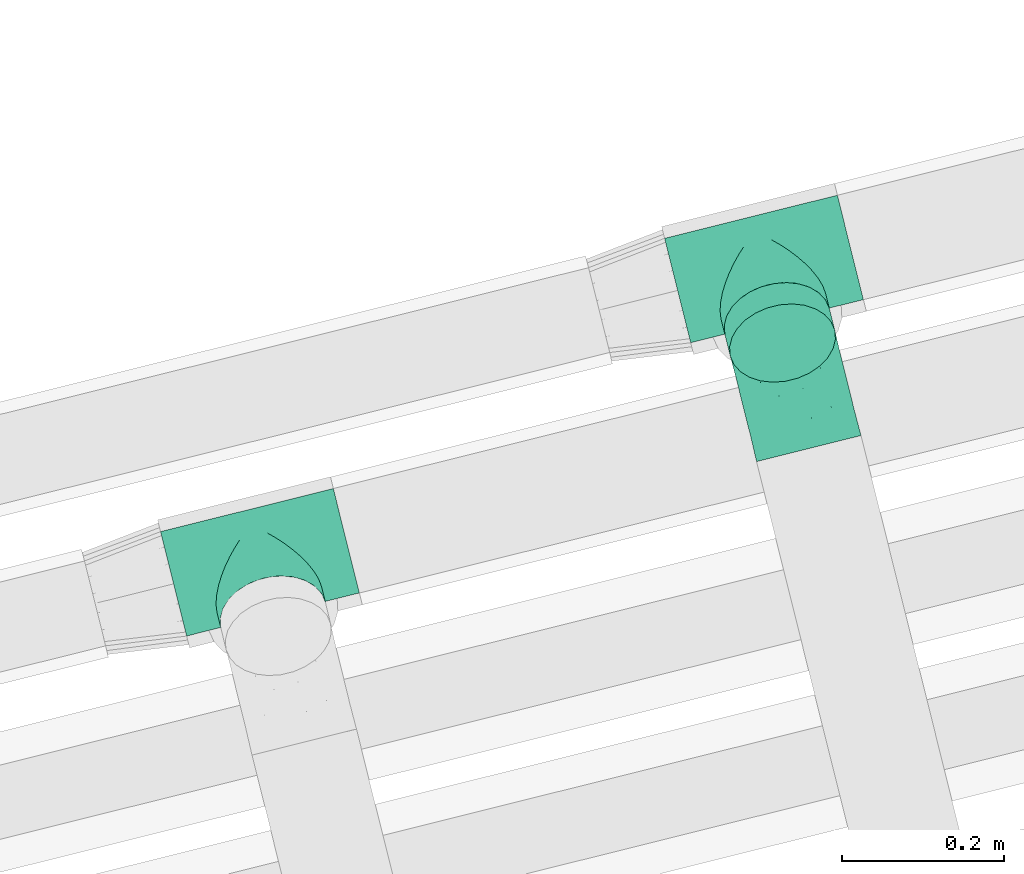
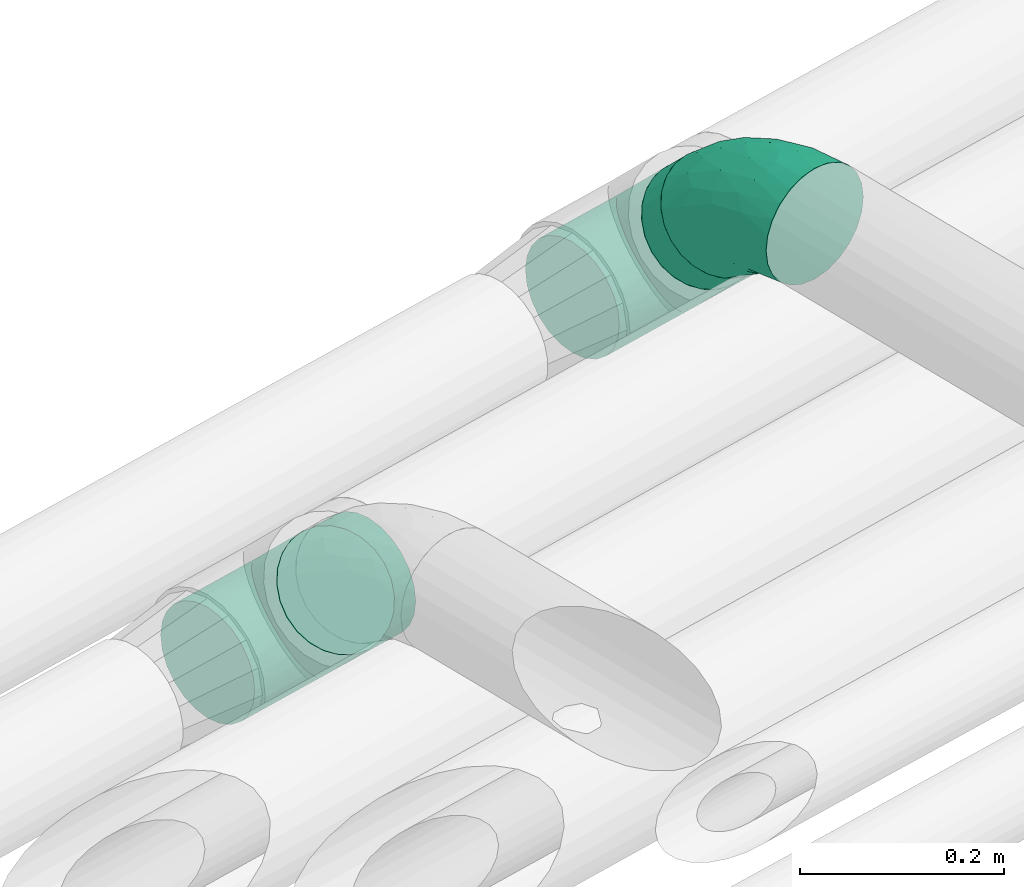
# One storey, part 55 of 93: 3 flow fittings, 1 flow segment.
"""IFC2X3 building model written with IfcOpenShell, lengths in millimetres."""

from ifc_helpers import new_model, entity, si_unit, converted_unit, derived_unit, direction, frame, origin, origin_2d_with_axis, place, context, subcontext, project, spatial, circle, extrude, faceted_brep, source, transform, mapped, material, type_object, type_shapes, element, save


model = new_model("IFC2X3")

# Units and contexts
model_context = context("Model", 3, precision=0.01, world=origin(), true_north=direction((6.12303176911189e-17, 1.0)))
body_context = subcontext(model_context, "Body", "Model", "MODEL_VIEW")
ifc_project = project(units=[si_unit("LENGTHUNIT", "METRE", prefix="MILLI"), si_unit("AREAUNIT", "SQUARE_METRE"), si_unit("VOLUMEUNIT", "CUBIC_METRE"), converted_unit("PLANEANGLEUNIT", "DEGREE", entity("IfcRatioMeasure", 0.0174532925199433), si_unit("PLANEANGLEUNIT", "RADIAN"), dimensions=[0, 0, 0, 0, 0, 0, 0]), si_unit("MASSUNIT", "GRAM", prefix="KILO"), derived_unit("MASSDENSITYUNIT", [(si_unit("MASSUNIT", "GRAM", prefix="KILO"), 1), (si_unit("LENGTHUNIT", "METRE"), -3)]), derived_unit("MOMENTOFINERTIAUNIT", [(si_unit("LENGTHUNIT", "METRE"), 4)]), si_unit("TIMEUNIT", "SECOND"), si_unit("FREQUENCYUNIT", "HERTZ"), si_unit("THERMODYNAMICTEMPERATUREUNIT", "DEGREE_CELSIUS"), derived_unit("THERMALTRANSMITTANCEUNIT", [(si_unit("MASSUNIT", "GRAM", prefix="KILO"), 1), (si_unit("THERMODYNAMICTEMPERATUREUNIT", "KELVIN"), -1), (si_unit("TIMEUNIT", "SECOND"), -3)]), derived_unit("VOLUMETRICFLOWRATEUNIT", [(si_unit("LENGTHUNIT", "METRE"), 3), (si_unit("TIMEUNIT", "SECOND"), -1)]), derived_unit("MASSFLOWRATEUNIT", [(si_unit("MASSUNIT", "GRAM", prefix="KILO"), 1), (si_unit("TIMEUNIT", "SECOND"), -1)]), derived_unit("ROTATIONALFREQUENCYUNIT", [(si_unit("TIMEUNIT", "SECOND"), -1)]), si_unit("ELECTRICCURRENTUNIT", "AMPERE"), si_unit("ELECTRICVOLTAGEUNIT", "VOLT"), si_unit("POWERUNIT", "WATT"), si_unit("FORCEUNIT", "NEWTON", prefix="KILO"), si_unit("ILLUMINANCEUNIT", "LUX"), si_unit("LUMINOUSFLUXUNIT", "LUMEN"), si_unit("LUMINOUSINTENSITYUNIT", "CANDELA"), derived_unit("USERDEFINED", [(si_unit("MASSUNIT", "GRAM", prefix="KILO"), -1), (si_unit("LENGTHUNIT", "METRE"), -2), (si_unit("TIMEUNIT", "SECOND"), 3), (si_unit("LUMINOUSFLUXUNIT", "LUMEN"), 1)]), derived_unit("LINEARVELOCITYUNIT", [(si_unit("LENGTHUNIT", "METRE"), 1), (si_unit("TIMEUNIT", "SECOND"), -1)]), si_unit("PRESSUREUNIT", "PASCAL"), derived_unit("USERDEFINED", [(si_unit("LENGTHUNIT", "METRE"), -2), (si_unit("MASSUNIT", "GRAM", prefix="KILO"), 1), (si_unit("TIMEUNIT", "SECOND"), -2)]), derived_unit("LINEARFORCEUNIT", [(si_unit("MASSUNIT", "GRAM", prefix="KILO"), 1), (si_unit("LENGTHUNIT", "METRE"), 1), (si_unit("TIMEUNIT", "SECOND"), -2), (si_unit("LENGTHUNIT", "METRE"), -1)]), derived_unit("PLANARFORCEUNIT", [(si_unit("MASSUNIT", "GRAM", prefix="KILO"), 1), (si_unit("LENGTHUNIT", "METRE"), 1), (si_unit("TIMEUNIT", "SECOND"), -2), (si_unit("LENGTHUNIT", "METRE"), -2)])], contexts=[model_context])

# Site, building, storey
site_placement = place(None, origin())
site = spatial("IfcSite", under=ifc_project, at=site_placement, CompositionType="ELEMENT")
building_placement = place(site_placement, origin())
building = spatial("IfcBuilding", under=site, at=building_placement, CompositionType="ELEMENT")
storey_placement = place(building_placement, frame((0.0, 0.0, -4200.0)))
storey = spatial("IfcBuildingStorey", under=building, at=storey_placement, CompositionType="ELEMENT", Elevation=-4200.0)

# Flow segment
pipe_segment_type = type_object("IfcPipeSegmentType", PredefinedType="NOTDEFINED")
flow_segment_placement = place(storey_placement, frame((-9316.64, 13413.67, 2518.56)))
element("IfcFlowSegment", 1, at=flow_segment_placement, inside=storey, type_object=pipe_segment_type, context=body_context, shape_type="SweptSolid", body=[
    extrude(circle(Radius=66.5, at=origin_2d_with_axis()), frame((73.44, 49.83, 75.79), z_axis=(-0.171064612896027, 0.686102687806118, -0.707106781186514), x_axis=(-0.970295726276, -0.241921895599653, 0.0)), (0.0, 0.0, 1.0), 38.4297928148945),
])

# Flow fittings
ifc_material = material()
pipe_fitting_type_1 = type_object("IfcPipeFittingType", Name="ADSK_2", PredefinedType="NOTDEFINED", material=ifc_material)
shared_shape_1 = source(origin(), body_context, "Body", "Brep", [
    faceted_brep([(-110.0, 33.25, -57.59), (-110.0, 17.21, -64.23), (-110.0, 0.0, -66.5), (-110.0, -17.21, -64.23), (-110.0, -33.25, -57.59), (-110.0, -40.14, -52.31), (-110.0, -47.02, -47.02), (-110.0, -52.31, -40.14), (-110.0, -57.59, -33.25), (-110.0, -60.91, -25.23), (-110.0, -64.23, -17.21), (-110.0, -65.37, -8.61), (-110.0, -66.5, 0.0), (-110.0, -65.37, 8.61), (-110.0, -64.23, 17.21), (-110.0, -60.91, 25.23), (-110.0, -57.59, 33.25), (-110.0, -52.31, 40.14), (-110.0, -47.02, 47.02), (-110.0, -40.14, 52.31), (-110.0, -33.25, 57.59), (-110.0, -17.21, 64.23), (-110.0, 0.0, 66.5), (-110.0, 17.21, 64.23), (-110.0, 33.25, 57.59), (-110.0, 47.02, 47.02), (-110.0, 57.59, 33.25), (-110.0, 64.23, 17.21), (-110.0, 66.5, 0.0), (-110.0, 64.23, -17.21), (-110.0, 57.59, -33.25), (-110.0, 47.02, -47.02), (110.0, 0.0, -66.5), (110.0, 17.21, -64.23), (110.0, 33.25, -57.59), (110.0, 47.02, -47.02), (110.0, 57.59, -33.25), (110.0, 64.23, -17.21), (110.0, 66.5, 0.0), (110.0, 64.23, 17.21), (110.0, 57.59, 33.25), (110.0, 47.02, 47.02), (110.0, 33.25, 57.59), (110.0, 17.21, 64.23), (110.0, 0.0, 66.5), (110.0, -17.21, 64.23), (110.0, -33.25, 57.59), (110.0, -40.14, 52.31), (110.0, -47.02, 47.02), (110.0, -52.31, 40.14), (110.0, -57.59, 33.25), (110.0, -60.91, 25.23), (110.0, -64.23, 17.21), (110.0, -65.37, 8.61), (110.0, -66.5, 0.0), (110.0, -65.37, -8.61), (110.0, -64.23, -17.21), (110.0, -60.91, -25.23), (110.0, -57.59, -33.25), (110.0, -52.31, -40.14), (110.0, -47.02, -47.02), (110.0, -40.14, -52.31), (110.0, -33.25, -57.59), (110.0, -17.21, -64.23), (65.3, -65.3, 12.57), (65.9, -65.9, 6.28), (63.6, -63.6, 18.43), (61.9, -61.9, 24.3), (56.74, -56.74, 34.68), (50.29, -50.29, 43.51), (42.94, -42.94, 50.78), (34.95, -34.95, 56.57), (-65.9, -65.9, 6.28), (-61.9, -61.9, 24.3), (-63.6, -63.6, 18.43), (-65.3, -65.3, 12.57), (-66.5, -66.5, 0.0), (66.5, -66.5, 0.0), (-56.74, -56.74, 34.68), (-34.95, -34.95, 56.57), (-50.29, -50.29, 43.51), (-42.94, -42.94, 50.78), (-26.54, -26.54, 60.98), (26.54, -26.54, 60.98), (8.96, -8.96, 65.89), (17.83, -17.83, 64.06), (0.0, 0.0, 66.5), (-8.96, -8.96, 65.89), (-17.83, -17.83, 64.06), (0.0, 0.0, -66.5), (8.96, -8.96, -65.89), (-56.74, -56.74, -34.68), (-50.29, -50.29, -43.51), (17.83, -17.83, -64.06), (26.54, -26.54, -60.98), (34.95, -34.95, -56.57), (42.94, -42.94, -50.78), (-8.96, -8.96, -65.89), (-63.6, -63.6, -18.43), (-61.9, -61.9, -24.3), (-65.9, -65.9, -6.28), (65.9, -65.9, -6.28), (-17.83, -17.83, -64.06), (-26.54, -26.54, -60.98), (-42.94, -42.94, -50.78), (50.29, -50.29, -43.51), (56.74, -56.74, -34.68), (-65.3, -65.3, -12.57), (65.3, -65.3, -12.57), (63.6, -63.6, -18.43), (61.9, -61.9, -24.3), (-34.95, -34.95, -56.57), (0.0, -95.0, -66.5), (17.21, -95.0, -64.23), (33.25, -95.0, -57.59), (47.02, -95.0, -47.02), (57.59, -95.0, -33.25), (60.91, -95.0, -25.23), (64.23, -95.0, -17.21), (65.37, -95.0, -8.61), (66.5, -95.0, 0.0), (65.37, -95.0, 8.61), (64.23, -95.0, 17.21), (60.91, -95.0, 25.23), (57.59, -95.0, 33.25), (47.02, -95.0, 47.02), (33.25, -95.0, 57.59), (17.21, -95.0, 64.23), (0.0, -95.0, 66.5), (-17.21, -95.0, 64.23), (-33.25, -95.0, 57.59), (-47.02, -95.0, 47.02), (-57.59, -95.0, 33.25), (-60.91, -95.0, 25.23), (-64.23, -95.0, 17.21), (-65.37, -95.0, 8.61), (-66.5, -95.0, 0.0), (-65.37, -95.0, -8.61), (-64.23, -95.0, -17.21), (-60.91, -95.0, -25.23), (-57.59, -95.0, -33.25), (-47.02, -95.0, -47.02), (-33.25, -95.0, -57.59), (-17.21, -95.0, -64.23)], [[[0, 1, 2, 3, 4, 5, 6, 7, 8, 9, 10, 11, 12, 13, 14, 15, 16, 17, 18, 19, 20, 21, 22, 23, 24, 25, 26, 27, 28, 29, 30, 31]], [[32, 33, 34, 35, 36, 37, 38, 39, 40, 41, 42, 43, 44, 45, 46, 47, 48, 49, 50, 51, 52, 53, 54, 55, 56, 57, 58, 59, 60, 61, 62, 63]], [[53, 52, 64]], [[54, 53, 65]], [[66, 64, 52]], [[51, 50, 67]], [[50, 49, 68]], [[69, 49, 48]], [[50, 68, 67]], [[70, 48, 47]], [[70, 69, 48]], [[71, 70, 47]], [[12, 72, 13]], [[47, 46, 71]], [[66, 51, 67]], [[73, 15, 74]], [[75, 13, 72]], [[12, 76, 72]], [[54, 65, 77]], [[74, 15, 14]], [[73, 78, 16]], [[79, 20, 19]], [[80, 81, 18]], [[16, 78, 17]], [[18, 81, 19]], [[17, 78, 80]], [[20, 79, 82]], [[53, 64, 65]], [[68, 49, 69]], [[83, 46, 45]], [[84, 45, 44]], [[75, 14, 13]], [[85, 83, 45]], [[84, 85, 45]], [[80, 18, 17]], [[84, 44, 86]], [[87, 86, 22]], [[51, 66, 52]], [[26, 25, 41, 40]], [[27, 26, 40, 39]], [[24, 23, 43, 42]], [[25, 24, 42, 41]], [[43, 23, 22, 86, 44]], [[28, 27, 39, 38]], [[73, 16, 15]], [[14, 75, 74]], [[88, 87, 21]], [[88, 21, 82]], [[21, 87, 22]], [[82, 21, 20]], [[79, 19, 81]], [[83, 71, 46]], [[31, 30, 36, 35]], [[29, 37, 36, 30]], [[28, 38, 37, 29]], [[0, 31, 35, 34]], [[32, 89, 2, 1, 33]], [[90, 32, 63]], [[91, 7, 92]], [[93, 90, 63]], [[94, 93, 63]], [[95, 61, 96]], [[63, 62, 94]], [[34, 33, 1, 0]], [[32, 90, 89]], [[89, 97, 2]], [[98, 9, 99]], [[12, 100, 76]], [[54, 77, 101]], [[97, 102, 3]], [[97, 3, 2]], [[3, 102, 103]], [[3, 103, 4]], [[104, 6, 5]], [[105, 60, 59]], [[96, 61, 60]], [[106, 59, 58]], [[105, 59, 106]], [[11, 107, 100]], [[95, 62, 61]], [[105, 96, 60]], [[56, 108, 109]], [[110, 58, 57]], [[57, 56, 109]], [[110, 57, 109]], [[108, 55, 101]], [[58, 110, 106]], [[54, 101, 55]], [[9, 98, 10]], [[104, 92, 6]], [[104, 5, 111]], [[5, 4, 111]], [[7, 6, 92]], [[7, 91, 8]], [[108, 56, 55]], [[4, 103, 111]], [[12, 11, 100]], [[98, 107, 10]], [[99, 9, 8]], [[10, 107, 11]], [[99, 8, 91]], [[94, 62, 95]], [[112, 113, 114, 115, 116, 117, 118, 119, 120, 121, 122, 123, 124, 125, 126, 127, 128, 129, 130, 131, 132, 133, 134, 135, 136, 137, 138, 139, 140, 141, 142, 143]], [[135, 134, 75]], [[135, 75, 72, 76]], [[76, 136, 135]], [[134, 73, 74, 75]], [[131, 130, 81]], [[80, 132, 131]], [[73, 134, 133, 132]], [[82, 130, 129]], [[78, 73, 132]], [[81, 80, 131]], [[78, 132, 80]], [[82, 79, 130]], [[87, 88, 129]], [[128, 86, 87]], [[82, 129, 88]], [[81, 130, 79]], [[67, 124, 123, 122]], [[87, 129, 128]], [[126, 83, 127]], [[127, 84, 128]], [[70, 126, 125]], [[121, 120, 77]], [[125, 124, 69]], [[121, 77, 65, 64]], [[71, 83, 126]], [[85, 84, 127]], [[83, 85, 127]], [[122, 64, 66, 67]], [[64, 122, 121]], [[69, 70, 125]], [[68, 69, 124]], [[67, 68, 124]], [[71, 126, 70]], [[128, 84, 86]], [[119, 118, 108]], [[110, 118, 117, 116]], [[77, 120, 119]], [[118, 110, 109, 108]], [[107, 138, 137]], [[105, 116, 115]], [[119, 108, 101, 77]], [[115, 114, 96]], [[94, 114, 113]], [[106, 110, 116]], [[96, 105, 115]], [[106, 116, 105]], [[94, 95, 114]], [[90, 93, 113]], [[112, 89, 90]], [[94, 113, 93]], [[96, 114, 95]], [[90, 113, 112]], [[142, 103, 143]], [[143, 97, 112]], [[104, 142, 141]], [[137, 136, 76]], [[141, 140, 92]], [[138, 99, 140, 139]], [[137, 76, 100, 107]], [[111, 103, 142]], [[102, 97, 143]], [[103, 102, 143]], [[138, 107, 98, 99]], [[92, 104, 141]], [[91, 92, 140]], [[99, 91, 140]], [[111, 142, 104]], [[112, 97, 89]]]),
])
type_shapes(pipe_fitting_type_1, [shared_shape_1])
for number, where, z_axis, x_axis, name in (
    (2, (-9266.02, 13555.04, 2500.0), (0.171064612896022, -0.686102687806058, -0.707106781186573), (-0.970295726276004, -0.241921895599639, 0.0), "ADSK_2"),
    (3, (-9888.84, 13192.62, 2499.91), (0.171064612896062, -0.686102687806076, -0.707106781186546), (-0.970295726275991, -0.24192189559969, 0.0), "ADSK_2"),
):
    element("IfcFlowFitting", number, at=place(storey_placement, frame(where, z_axis=z_axis, x_axis=x_axis)), inside=storey, type_object=pipe_fitting_type_1, material=ifc_material, Name=name, ObjectType="ADSK_2", context=body_context, shape_type="MappedRepresentation", body=[
        mapped(shared_shape_1, transform((0.0, 0.0, 0.0), scale=1.0)),
    ])
pipe_fitting_type_2 = type_object("IfcPipeFittingType", Name="ADSK_2", PredefinedType="NOTDEFINED", material=ifc_material)
shared_shape_2 = source(origin(), body_context, "Body", "Brep", [
    faceted_brep([(-78.7, 33.25, -57.59), (-78.7, 17.21, -64.23), (-78.7, 0.0, -66.5), (-78.7, -17.21, -64.23), (-78.7, -33.25, -57.59), (-78.7, -47.02, -47.02), (-78.7, -57.59, -33.25), (-78.7, -64.23, -17.21), (-78.7, -66.5, 0.0), (-78.7, -64.23, 17.21), (-78.7, -57.59, 33.25), (-78.7, -47.02, 47.02), (-78.7, -33.25, 57.59), (-78.7, -17.21, 64.23), (-78.7, 0.0, 66.5), (-78.7, 17.21, 64.23), (-78.7, 33.25, 57.59), (-78.7, 47.02, 47.02), (-78.7, 57.59, 33.25), (-78.7, 64.23, 17.21), (-78.7, 66.5, 0.0), (-78.7, 64.23, -17.21), (-78.7, 57.59, -33.25), (-78.7, 47.02, -47.02), (55.65, 55.65, -66.5), (43.48, 67.82, -64.23), (32.14, 79.16, -57.59), (22.4, 88.9, -47.02), (14.93, 96.37, -33.25), (10.23, 101.07, -17.21), (8.63, 102.67, 0.0), (10.23, 101.07, 17.21), (14.93, 96.37, 33.25), (22.4, 88.9, 47.02), (32.14, 79.16, 57.59), (43.48, 67.82, 64.23), (55.65, 55.65, 66.5), (67.82, 43.48, 64.23), (79.16, 32.14, 57.59), (88.9, 22.4, 47.02), (96.37, 14.93, 33.25), (101.07, 10.23, 17.21), (102.67, 8.63, 0.0), (101.07, 10.23, -17.21), (96.37, 14.93, -33.25), (88.9, 22.4, -47.02), (79.16, 32.14, -57.59), (67.82, 43.48, -64.23), (-40.01, -57.38, 27.86), (-40.6, -61.75, 15.74), (-6.41, -52.87, 20.07), (-28.66, -61.57, 0.0), (44.74, 12.16, 61.0), (-23.71, -35.12, 51.77), (8.73, -21.07, 54.25), (-40.23, -23.04, 61.0), (-34.61, -49.5, 39.47), (-28.9, -3.87, 65.72), (-8.47, 20.45, 66.18), (-47.15, 10.46, 66.05), (-49.81, 55.22, 41.25), (-33.77, 66.88, 30.79), (-20.88, 50.42, 53.92), (7.4, 48.4, 61.91), (-34.71, 30.07, 61.97), (42.4, -35.06, 11.04), (19.46, -46.98, 0.0), (63.8, -23.27, 0.0), (-15.18, 67.35, 41.6), (14.82, -35.78, 38.27), (53.98, -24.32, 23.88), (-30.55, 73.76, 17.41), (-46.74, 70.71, 0.0), (59.47, -10.53, 39.47), (-16.95, 83.05, 0.0), (25.95, 40.74, 66.05), (41.59, -8.07, 51.77), (23.18, 17.7, 65.72), (74.36, -14.41, 12.26), (4.62, -11.15, 60.44), (-39.45, 28.99, -61.91), (-20.88, 50.42, -53.92), (3.28, 45.81, -61.97), (-23.41, 71.18, -30.79), (8.73, -21.07, -54.25), (4.62, -11.15, -60.44), (44.74, 12.16, -61.0), (-30.55, 73.76, -17.41), (-40.23, -23.04, -61.0), (-23.71, -35.12, -51.77), (-36.89, 58.36, -41.6), (-47.15, 10.46, -66.05), (-28.9, -3.87, -65.72), (-20.98, -55.37, -23.88), (-34.61, -49.5, -39.47), (68.86, -12.28, -27.86), (59.47, -10.53, -39.47), (-42.39, -62.77, -12.26), (41.59, -8.07, -51.77), (14.82, -35.78, -38.27), (41.92, -32.85, -20.07), (-5.19, -54.78, -11.04), (72.37, -14.95, -15.74), (-3.83, 74.27, -41.25), (25.95, 40.74, -66.05), (23.18, 17.7, -65.72), (-8.47, 20.45, -66.18)], [[[0, 1, 2, 3, 4, 5, 6, 7, 8, 9, 10, 11, 12, 13, 14, 15, 16, 17, 18, 19, 20, 21, 22, 23]], [[24, 25, 26, 27, 28, 29, 30, 31, 32, 33, 34, 35, 36, 37, 38, 39, 40, 41, 42, 43, 44, 45, 46, 47]], [[48, 49, 50]], [[49, 8, 51]], [[38, 37, 52]], [[12, 11, 53]], [[53, 54, 55]], [[56, 11, 10]], [[14, 13, 57]], [[13, 12, 55]], [[57, 58, 59]], [[60, 61, 18]], [[62, 63, 34]], [[18, 61, 19]], [[16, 15, 64]], [[17, 16, 62]], [[65, 66, 67]], [[60, 62, 68]], [[15, 14, 59]], [[34, 33, 62]], [[69, 50, 70]], [[19, 71, 72]], [[40, 39, 73]], [[72, 20, 19]], [[74, 71, 31]], [[50, 66, 65]], [[62, 16, 64]], [[56, 48, 69]], [[66, 50, 51]], [[36, 35, 75]], [[39, 38, 76]], [[76, 73, 39]], [[32, 31, 61]], [[75, 77, 36]], [[70, 41, 40]], [[77, 37, 36]], [[48, 56, 10]], [[70, 40, 73]], [[59, 64, 15]], [[76, 38, 52]], [[58, 75, 63]], [[42, 41, 78]], [[53, 56, 69]], [[17, 60, 18]], [[54, 79, 55]], [[72, 71, 74]], [[48, 9, 49]], [[30, 74, 31]], [[54, 69, 76]], [[31, 71, 61]], [[58, 57, 77]], [[32, 68, 33]], [[55, 57, 13]], [[68, 62, 33]], [[79, 52, 77]], [[35, 34, 63]], [[63, 62, 64]], [[73, 76, 69]], [[79, 77, 57]], [[78, 70, 65]], [[70, 73, 69]], [[56, 53, 11]], [[58, 63, 64]], [[53, 55, 12]], [[57, 55, 79]], [[77, 52, 37]], [[52, 79, 54]], [[57, 59, 14]], [[64, 59, 58]], [[63, 75, 35]], [[77, 75, 58]], [[62, 60, 17]], [[61, 60, 68]], [[32, 61, 68]], [[61, 71, 19]], [[9, 48, 10]], [[69, 48, 50]], [[8, 49, 9]], [[51, 50, 49]], [[78, 65, 67]], [[50, 65, 70]], [[42, 78, 67]], [[70, 78, 41]], [[69, 54, 53]], [[52, 54, 76]], [[1, 0, 80]], [[81, 82, 80]], [[28, 83, 29]], [[23, 81, 0]], [[20, 72, 21]], [[84, 85, 86]], [[21, 87, 83]], [[88, 89, 4]], [[81, 23, 90]], [[91, 92, 2]], [[26, 25, 82]], [[91, 2, 1]], [[93, 6, 94]], [[95, 96, 44]], [[8, 7, 97]], [[81, 80, 0]], [[93, 7, 6]], [[98, 96, 99]], [[88, 4, 3]], [[100, 66, 101]], [[6, 5, 94]], [[89, 5, 4]], [[2, 92, 3]], [[94, 89, 99]], [[93, 94, 99]], [[96, 98, 45]], [[87, 72, 74]], [[89, 94, 5]], [[74, 30, 29]], [[99, 100, 93]], [[72, 87, 21]], [[95, 43, 102]], [[103, 83, 28]], [[90, 103, 81]], [[26, 82, 81]], [[46, 45, 98]], [[104, 25, 24]], [[96, 95, 99]], [[22, 90, 23]], [[26, 81, 27]], [[84, 99, 89]], [[104, 105, 106]], [[84, 86, 98]], [[27, 103, 28]], [[24, 47, 105]], [[67, 66, 100]], [[44, 96, 45]], [[47, 46, 86]], [[100, 95, 102]], [[85, 92, 105]], [[67, 102, 42]], [[85, 88, 92]], [[106, 105, 92]], [[97, 93, 101]], [[22, 21, 83]], [[101, 66, 51]], [[104, 82, 25]], [[87, 74, 29]], [[106, 91, 80]], [[86, 105, 47]], [[106, 80, 82]], [[92, 88, 3]], [[88, 85, 84]], [[98, 86, 46]], [[105, 86, 85]], [[80, 91, 1]], [[92, 91, 106]], [[105, 104, 24]], [[82, 104, 106]], [[81, 103, 27]], [[83, 103, 90]], [[22, 83, 90]], [[83, 87, 29]], [[43, 95, 44]], [[99, 95, 100]], [[42, 102, 43]], [[67, 100, 102]], [[97, 101, 51]], [[100, 101, 93]], [[8, 97, 51]], [[93, 97, 7]], [[99, 84, 98]], [[88, 84, 89]]]),
])
type_shapes(pipe_fitting_type_2, [shared_shape_2])
flow_fitting_placement = place(storey_placement, frame((-9229.73, 13409.5, 2650.0), z_axis=(0.970295726276004, 0.241921895599638, 0.0), x_axis=(0.171064612896032, -0.686102687806108, 0.707106781186523)))
element("IfcFlowFitting", 4, at=flow_fitting_placement, inside=storey, type_object=pipe_fitting_type_2, material=ifc_material, Name="ADSK_2", ObjectType="ADSK_2", context=body_context, shape_type="MappedRepresentation", body=[
    mapped(shared_shape_2, transform((0.0, 0.0, 0.0), scale=1.0)),
])

save(model, "model.ifc")
